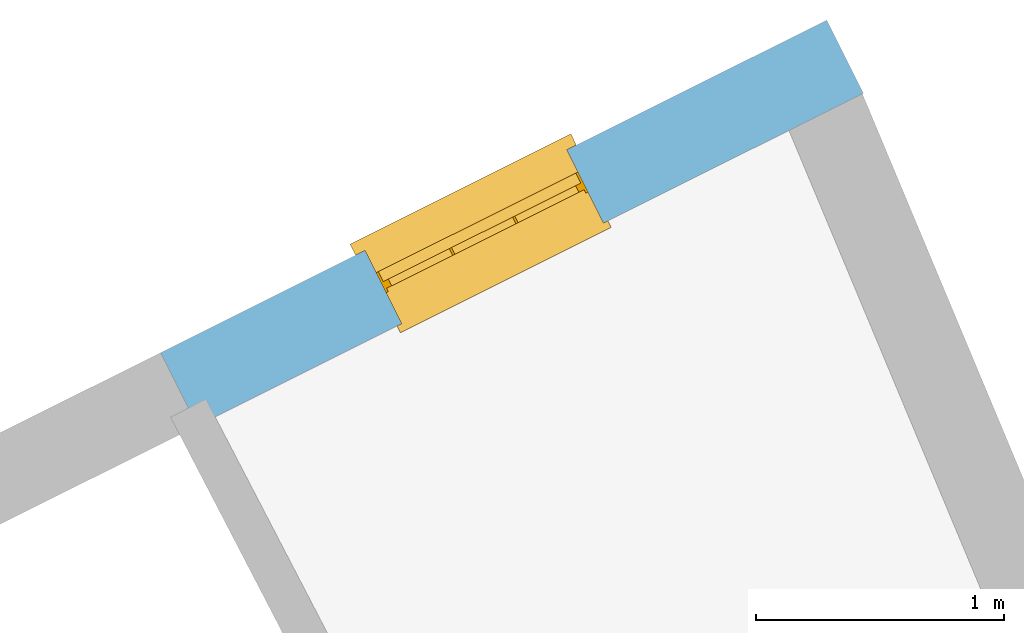
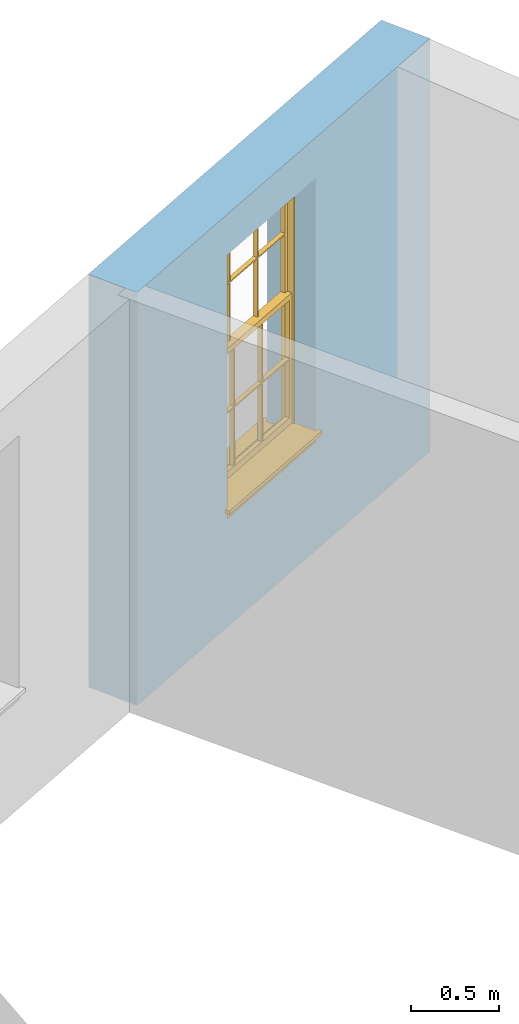
# One storey, part 7 of 9: 1 window, 1 opening, plus 1 element that does not belong to this part.
"""IFC2X3 building model written with IfcOpenShell, lengths in metres."""

from ifc_helpers import new_model, si_unit, frame, origin, place, context, subcontext, project, spatial, polyline, outline, extrude, faceted_brep, material, layer, layer_set, layer_usage, element, fill, save


model = new_model("IFC2X3")

# Units and contexts
model_context = context("Model", 3, world=origin())
body_context = subcontext(model_context, "Body", "Model", "MODEL_VIEW")
ifc_project = project(units=[si_unit("PLANEANGLEUNIT", "RADIAN"), si_unit("MASSUNIT", "GRAM", prefix="KILO"), si_unit("FORCEUNIT", "NEWTON", prefix="KILO"), si_unit("LENGTHUNIT", "METRE")], contexts=[model_context])

# Site, building, storey
site_placement = place(None, origin())
site = spatial("IfcSite", under=ifc_project, at=site_placement, CompositionType="ELEMENT")
building_placement = place(None, origin())
building = spatial("IfcBuilding", under=site, at=building_placement, Name="Building plot-8", CompositionType="ELEMENT")
storey_placement = place(None, frame((0.0, 0.0, 3.45)))
storey = spatial("IfcBuildingStorey", under=building, at=storey_placement, Name="Floor 1", CompositionType="ELEMENT", Elevation=3.45)

# Wall, opening, window
ifc_material = material(Name="Masonry")
ifc_layer = layer(ifc_material, 0.33, ventilated=False)
ifc_layer_set = layer_set([ifc_layer], Name="My Wall")
ifc_layer_usage = layer_usage(ifc_layer_set, "AXIS2", "NEGATIVE", 0.08)
wall_placement = place(storey_placement, origin())
wall = element("IfcWallStandardCase", 1, at=wall_placement, inside=storey, material=ifc_layer_usage, Name="exterior", context=body_context, shape_type="SweptSolid", body=[
    extrude(outline(polyline([(28.1976396877446, 19.9353489269842), (28.0502378466283, 20.230599155156), (25.3643689149095, 18.889695786567), (25.5117707560258, 18.5944455583952), (28.1976396877446, 19.9353489269842)])), origin(), (0.0, 0.0, 1.0), 2.85),
])
opening_placement = place(storey_placement, frame((0.0, 0.0, 0.75)))
opening = element("IfcOpeningElement", 2, at=opening_placement, cuts=wall, Name="Opening", ObjectType="Opening", context=body_context, shape_type="SweptSolid", body=[
    extrude(outline(polyline([(27.0025536089408, 19.7075493119778), (26.1883787373153, 19.3010775682935), (26.3357805784316, 19.0058273401217), (27.149955450057, 19.4122990838059), (27.0025536089408, 19.7075493119778)])), origin(), (0.0, 0.0, 1.0), 1.82),
])
window_placement = place(storey_placement, frame((27.1142216703925, 19.4838748966961, 0.75), z_axis=(0.0, 0.0, 1.0), x_axis=(-0.814174871625433, -0.406471743684243, 0.0)))
window = element("IfcWindow", 3, at=window_placement, inside=storey, Name="bedroom outside window", OverallHeight=1.82, OverallWidth=0.91, context=body_context, shape_type="Brep", held_by="IfcProductRepresentation", body=[
    faceted_brep([(0.033125, -0.105, 0.975209), (0.01, -0.105, 0.975209), (0.033125, -0.105, 1.376042), (0.876875, -0.105, 0.975209), (0.876875, -0.105, 1.376042), (0.9, -0.105, 0.975209), (0.876875, -0.105, 1.386042), (0.876875, -0.105, 1.786875), (0.9, -0.105, 1.81), (0.033125, -0.105, 1.786875), (0.033125, -0.105, 1.386042), (0.01, -0.105, 1.81), (0.876875, -0.135, 1.376042), (0.876875, -0.135, 0.975209), (0.9, -0.135, 0.937083), (0.033125, -0.135, 1.786875), (0.01, -0.135, 1.81), (0.033125, -0.135, 1.386042), (0.01, -0.135, 0.937083), (0.033125, -0.135, 0.975209), (0.033125, -0.135, 1.376042), (0.876875, -0.135, 1.786875), (0.876875, -0.135, 1.386042), (0.9, -0.135, 1.81), (0.033125, -0.105, 0.937083), (0.01, -0.105, 0.937083), (0.033125, -0.105, 0.53625), (0.876875, -0.105, 0.937083), (0.876875, -0.105, 0.53625), (0.9, -0.105, 0.937083), (0.876875, -0.105, 0.52625), (0.876875, -0.105, 0.125417), (0.9, -0.105, 0.077167), (0.033125, -0.105, 0.125417), (0.033125, -0.105, 0.52625), (0.01, -0.105, 0.077167), (-0.0425, -0.25, 0.01), (-0.0425, -0.3, 0.001667), (0.0, -0.25, 0.01), (0.9525, -0.25, 0.01), (0.91, -0.25, 0.01), (0.9525, -0.3, 0.001667), (-0.02, 0.08, 0.077167), (0.0, 0.08, 0.077167), (-0.02, 0.11, 0.077167), (0.0, -0.06, 0.077167), (0.01, -0.06, 0.077167), (0.91, -0.06, 0.077167), (0.91, 0.08, 0.077167), (0.9, -0.06, 0.077167), (0.93, 0.08, 0.077167), (0.93, 0.11, 0.077167), (0.01, -0.075, 0.975209), (0.9, -0.075, 0.975209), (0.876875, -0.075, 0.125417), (0.876875, -0.075, 0.52625), (0.9, -0.075, 0.077167), (0.876875, -0.075, 0.53625), (0.876875, -0.075, 0.937083), (0.033125, -0.075, 0.125417), (0.01, -0.075, 0.077167), (0.033125, -0.075, 0.52625), (0.033125, -0.075, 0.937083), (0.033125, -0.075, 0.53625), (-0.02, 0.08, 0.052167), (-0.02, 0.11, 0.052167), (0.93, 0.11, 0.052167), (0.93, 0.08, 0.052167), (0.91, 0.08, 0.052167), (0.0, 0.08, 0.052167), (0.91, -0.15, 0.026667), (0.0, -0.15, 0.026667), (-0.0425, -0.3, -0.123333), (0.9525, -0.3, -0.123333), (-0.0425, -0.25, -0.123333), (0.9525, -0.25, -0.123333), (0.01, -0.06, 1.81), (0.9, -0.06, 1.81), (0.0, -0.06, 1.82), (0.91, -0.06, 1.82), (0.01, -0.15, 0.077167), (0.9, -0.15, 0.077167), (0.592292, -0.105, 0.125417), (0.592292, -0.075, 0.125417), (0.317708, -0.075, 0.125417), (0.317708, -0.105, 0.125417), (0.592292, -0.105, 0.53625), (0.317708, -0.105, 0.53625), (0.317708, -0.105, 0.52625), (0.592292, -0.105, 0.52625), (0.592292, -0.075, 0.53625), (0.317708, -0.075, 0.53625), (0.592292, -0.135, 1.386042), (0.592292, -0.105, 1.386042), (0.317708, -0.105, 1.386042), (0.317708, -0.135, 1.386042), (0.317708, -0.135, 1.376042), (0.592292, -0.135, 1.376042), (0.317708, -0.105, 1.376042), (0.592292, -0.105, 1.376042), (0.602292, -0.135, 1.376042), (0.592292, -0.135, 0.975209), (0.602292, -0.135, 0.975209), (0.602292, -0.105, 0.975209), (0.592292, -0.105, 0.975209), (0.602292, -0.105, 1.376042), (0.602292, -0.075, 0.53625), (0.602292, -0.105, 0.53625), (0.317708, -0.075, 0.52625), (0.307708, -0.075, 0.125417), (0.307708, -0.075, 0.52625), (0.602292, -0.075, 0.52625), (0.602292, -0.075, 0.125417), (0.592292, -0.075, 0.52625), (0.307708, -0.075, 0.53625), (0.317708, -0.075, 0.937083), (0.307708, -0.075, 0.937083), (0.602292, -0.075, 0.937083), (0.592292, -0.075, 0.937083), (0.307708, -0.105, 0.52625), (0.307708, -0.105, 0.125417), (0.307708, -0.105, 0.53625), (0.307708, -0.105, 0.937083), (0.592292, -0.105, 0.937083), (0.317708, -0.105, 0.937083), (0.602292, -0.105, 0.937083), (0.602292, -0.105, 0.52625), (0.602292, -0.105, 0.125417), (0.307708, -0.135, 1.386042), (0.307708, -0.135, 1.376042), (0.307708, -0.135, 0.975209), (0.317708, -0.135, 0.975209), (0.317708, -0.135, 1.786875), (0.307708, -0.135, 1.786875), (0.602292, -0.135, 1.786875), (0.592292, -0.135, 1.786875), (0.602292, -0.135, 1.386042), (0.602292, -0.105, 1.386042), (0.307708, -0.105, 1.386042), (0.307708, -0.105, 1.786875), (0.317708, -0.105, 1.786875), (0.592292, -0.105, 1.786875), (0.602292, -0.105, 1.786875), (0.307708, -0.105, 1.376042), (0.317708, -0.105, 0.975209), (0.307708, -0.105, 0.975209), (0.91, -0.15, 1.82), (0.9, -0.15, 1.81), (0.01, -0.15, 1.81), (0.0, -0.15, 1.82), (0.91, -0.25, 0.0), (0.0, -0.25, 0.0), (0.91, 0.08, 0.0), (0.0, 0.08, 0.0)], [[[0, 1, 2]], [[3, 4, 5]], [[6, 7, 8]], [[9, 10, 11]], [[12, 13, 14]], [[15, 16, 17]], [[18, 19, 20]], [[21, 22, 23]], [[24, 25, 26]], [[27, 28, 29]], [[30, 31, 32]], [[33, 34, 35]], [[14, 27, 29]], [[25, 24, 18]], [[36, 37, 38]], [[39, 40, 41]], [[42, 43, 44]], [[45, 46, 43]], [[47, 48, 49]], [[50, 51, 48]], [[1, 0, 52]], [[5, 53, 3]], [[54, 55, 56]], [[57, 58, 53]], [[59, 60, 61]], [[62, 63, 52]], [[48, 43, 46, 49]], [[51, 44, 43, 48]], [[64, 42, 44, 65]], [[65, 44, 51, 66]], [[66, 51, 50, 67]], [[65, 66, 68, 69]], [[60, 56, 49, 46]], [[70, 71, 38, 40]], [[37, 41, 40, 38]], [[37, 72, 73, 41]], [[74, 75, 73, 72]], [[8, 11, 76, 77]], [[76, 78, 79, 77]], [[32, 35, 80, 81]], [[81, 80, 71, 70]], [[82, 83, 84, 85]], [[86, 87, 88, 89]], [[86, 90, 91, 87]], [[92, 93, 94, 95]], [[92, 95, 96, 97]], [[96, 98, 99, 97]], [[100, 97, 101, 102]], [[103, 104, 99, 105]], [[97, 99, 104, 101]], [[102, 103, 105, 100]], [[28, 57, 106, 107]], [[108, 84, 109, 110]], [[111, 112, 83, 113]], [[114, 110, 61, 63]], [[90, 113, 108, 91]], [[115, 91, 114, 116]], [[117, 106, 90, 118]], [[111, 106, 57, 55]], [[119, 110, 109, 120]], [[34, 61, 110, 119]], [[89, 113, 83, 82]], [[88, 108, 113, 89]], [[85, 84, 108, 88]], [[121, 114, 63, 26]], [[122, 116, 114, 121]], [[123, 118, 90, 86]], [[87, 91, 115, 124]], [[107, 106, 117, 125]], [[126, 111, 55, 30]], [[127, 112, 111, 126]], [[126, 30, 28, 107]], [[88, 119, 120, 85]], [[126, 89, 82, 127]], [[125, 123, 86, 107]], [[121, 26, 34, 119]], [[124, 122, 121, 87]], [[128, 17, 20, 129]], [[96, 129, 130, 131]], [[132, 133, 128, 95]], [[134, 135, 92, 136]], [[100, 12, 22, 136]], [[137, 6, 4, 105]], [[94, 138, 139, 140]], [[137, 93, 141, 142]], [[99, 98, 94, 93]], [[143, 2, 10, 138]], [[144, 145, 143, 98]], [[129, 143, 145, 130]], [[20, 2, 143, 129]], [[131, 144, 98, 96]], [[128, 138, 10, 17]], [[133, 139, 138, 128]], [[135, 141, 93, 92]], [[95, 94, 140, 132]], [[22, 6, 137, 136]], [[136, 137, 142, 134]], [[100, 105, 4, 12]], [[107, 86, 89, 126]], [[106, 111, 113, 90]], [[91, 108, 110, 114]], [[87, 121, 119, 88]], [[97, 100, 136, 92]], [[129, 96, 95, 128]], [[98, 143, 138, 94]], [[105, 99, 93, 137]], [[131, 101, 104, 144]], [[124, 115, 118, 123]], [[132, 140, 141, 135]], [[120, 109, 59, 33]], [[15, 9, 139, 133]], [[134, 142, 7, 21]], [[31, 54, 112, 127]], [[36, 74, 72, 37]], [[39, 41, 73, 75]], [[18, 14, 101, 131]], [[23, 16, 132, 135]], [[83, 56, 60, 84]], [[52, 53, 118, 115]], [[53, 52, 144, 104]], [[11, 8, 141, 140]], [[14, 18, 124, 123]], [[2, 1, 11, 10]], [[8, 5, 4, 6]], [[57, 53, 56, 55]], [[60, 52, 63, 61]], [[26, 25, 35, 34]], [[32, 29, 28, 30]], [[14, 23, 22, 12]], [[18, 20, 17, 16]], [[19, 0, 2, 20]], [[17, 10, 9, 15]], [[12, 4, 3, 13]], [[21, 7, 6, 22]], [[27, 58, 57, 28]], [[30, 55, 54, 31]], [[33, 59, 61, 34]], [[26, 63, 62, 24]], [[5, 8, 77, 53]], [[76, 11, 1, 52]], [[46, 45, 78, 76]], [[49, 77, 79, 47]], [[70, 146, 147, 81]], [[71, 80, 148, 149]], [[19, 130, 145, 0]], [[102, 13, 3, 103]], [[116, 122, 24, 62]], [[29, 32, 81, 14]], [[80, 35, 25, 18]], [[60, 46, 76, 52]], [[77, 49, 56, 53]], [[23, 14, 81, 147]], [[16, 148, 80, 18]], [[35, 85, 120]], [[120, 33, 35]], [[127, 82, 32]], [[32, 31, 127]], [[32, 82, 85, 35]], [[102, 101, 14]], [[14, 13, 102]], [[18, 131, 130]], [[130, 19, 18]], [[134, 21, 23]], [[23, 135, 134]], [[16, 15, 133]], [[133, 132, 16]], [[11, 140, 139]], [[139, 9, 11]], [[142, 141, 8]], [[8, 7, 142]], [[23, 147, 148, 16]], [[146, 149, 148, 147]], [[52, 115, 116]], [[116, 62, 52]], [[118, 53, 117]], [[58, 117, 53]], [[27, 125, 117, 58]], [[56, 83, 112]], [[112, 54, 56]], [[109, 84, 60]], [[60, 59, 109]], [[125, 27, 14]], [[14, 123, 125]], [[122, 124, 18]], [[18, 24, 122]], [[145, 144, 52]], [[52, 0, 145]], [[103, 3, 53]], [[53, 104, 103]], [[79, 78, 149, 146]], [[78, 45, 71, 149]], [[146, 70, 47, 79]], [[150, 75, 74, 151]], [[68, 66, 67]], [[48, 68, 67, 50]], [[69, 64, 65]], [[42, 64, 69, 43]], [[69, 68, 152, 153]], [[70, 68, 48, 47]], [[150, 152, 68, 70]], [[43, 69, 71, 45]], [[69, 153, 151, 71]], [[152, 150, 151, 153]], [[38, 151, 74, 36]], [[71, 151, 38]], [[39, 75, 150, 40]], [[40, 150, 70]]]),
])
fill(opening, window)

save(model, "model.ifc")
